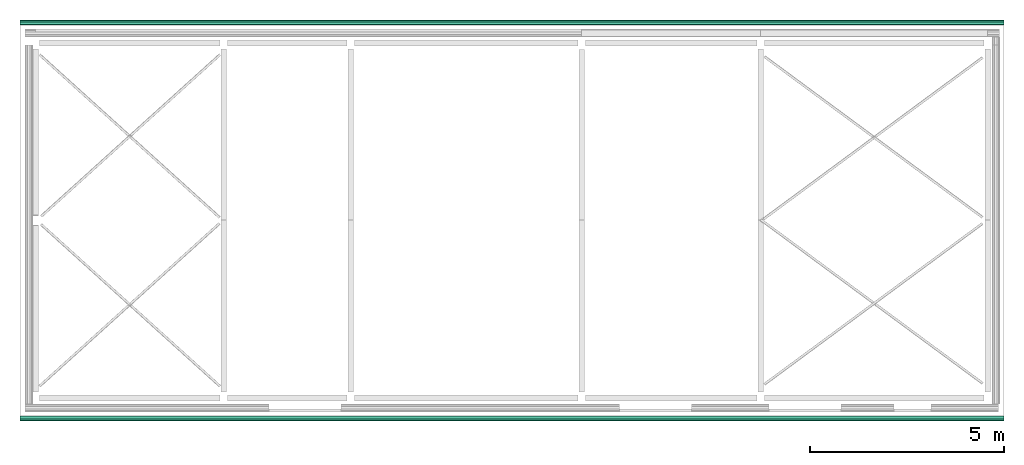
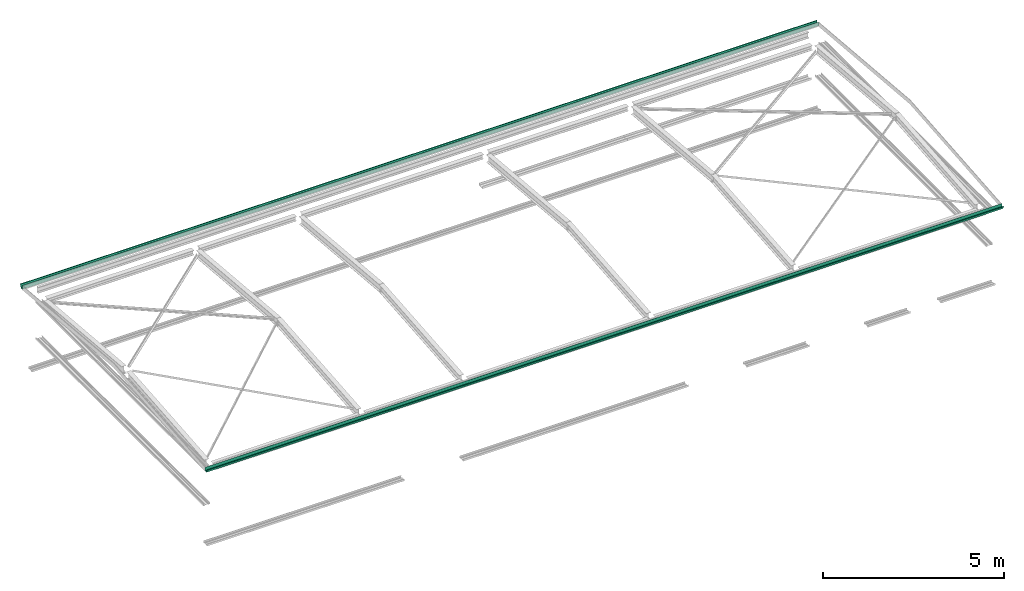
# One storey, part 4 of 8: 1 flow segment.
"""IFC2X3 building model written with IfcOpenShell, lengths in millimetres."""

from ifc_helpers import new_model, entity, si_unit, converted_unit, money_unit, direction, frame, origin_with_axes, place, context, subcontext, project, spatial, faceted_brep, material, material_list, type_object, element, save


model = new_model("IFC2X3")

# Units and contexts
model_context = context("Model", 3, precision=1e-05, world=origin_with_axes(), true_north=direction((0.0, 1.0)))
body_context = subcontext(model_context, "Body", "Model", "MODEL_VIEW")
ifc_project = project(units=[si_unit("LENGTHUNIT", "METRE", prefix="MILLI"), si_unit("AREAUNIT", "SQUARE_METRE"), si_unit("VOLUMEUNIT", "CUBIC_METRE"), converted_unit("PLANEANGLEUNIT", "DEGREE", entity("IfcPlaneAngleMeasure", 0.0174532925199), si_unit("PLANEANGLEUNIT", "RADIAN"), dimensions=[0, 0, 0, 0, 0, 0, 0]), si_unit("SOLIDANGLEUNIT", "STERADIAN"), money_unit("USD"), converted_unit("TIMEUNIT", "Year", entity("IfcTimeMeasure", 31556926.0), si_unit("TIMEUNIT", "SECOND"), dimensions=[0, 0, 0, 0, 0, 0, 0]), si_unit("MASSUNIT", "GRAM"), si_unit("THERMODYNAMICTEMPERATUREUNIT", "DEGREE_CELSIUS"), si_unit("LUMINOUSINTENSITYUNIT", "LUMEN")], contexts=[model_context])

# Site, building, storey
site_placement = place(None, origin_with_axes())
site = spatial("IfcSite", under=ifc_project, at=site_placement, CompositionType="ELEMENT")
building_placement = place(site_placement, origin_with_axes())
building = spatial("IfcBuilding", under=site, at=building_placement, CompositionType="ELEMENT")
storey_placement = place(building_placement, frame((0.0, 0.0, 74215.0), z_axis=(0.0, 0.0, 1.0), x_axis=(1.0, 0.0, 0.0)))
storey = spatial("IfcBuildingStorey", under=building, at=storey_placement, CompositionType="ELEMENT", Elevation=74215.0)

# Flow segment
ifc_material = material(Name="IFC Building Material")
ifc_material_list = material_list([ifc_material, ifc_material])
pipe_segment_type = type_object("IfcPipeSegmentType", Name="Gutter:Standard", PredefinedType="GUTTER")
flow_segment_placement = place(storey_placement, frame((-8525.22088657, -1586.32006319, 126.624724342), z_axis=(0.0, 0.0, 1.0), x_axis=(1.0, 0.0, 0.0)))
element("IfcFlowSegment", 1, at=flow_segment_placement, inside=storey, type_object=pipe_segment_type, material=ifc_material_list, Name="Gutter:Standard", ObjectType="Gutter:Standard", context=body_context, shape_type="Brep", body=[
    faceted_brep([(0.0, 10202.5999698, 0.0), (0.0, 10276.7999698, 0.0), (25352.2504249, 10276.7999698, 0.0), (25352.2504249, 10202.5999698, 0.0), (0.0, 10202.5999698, 124.912232528), (0.0, 10205.7749698, 124.912232528), (0.0, 10205.7749698, 3.175), (0.0, 10274.4376725, 3.175), (0.0, 10312.5376725, 102.687232528), (0.0, 10324.4249698, 102.687232528), (0.0, 10324.4249698, 109.037232528), (0.0, 10314.8999698, 109.037232528), (0.0, 10314.8999698, 112.212232528), (0.0, 10327.5999698, 112.212232528), (0.0, 10327.5999698, 99.5122325277), (0.0, 10314.8999698, 99.5122325277), (25352.2504249, 10314.8999698, 99.5122325277), (25352.2504249, 10327.5999698, 99.5122325277), (25352.2504249, 10327.5999698, 112.212232528), (25352.2504249, 10314.8999698, 112.212232528), (25352.2504249, 10314.8999698, 109.037232528), (25352.2504249, 10324.4249698, 109.037232528), (25352.2504249, 10324.4249698, 102.687232528), (25352.2504249, 10312.5376725, 102.687232528), (25352.2504249, 10274.4376725, 3.175), (25352.2504249, 10205.7749698, 3.175), (25352.2504249, 10205.7749698, 124.912232528), (25352.2504249, 10202.5999698, 124.912232528)], [[[0, 1, 2, 3]], [[0, 4, 5, 6, 7, 8, 9, 10, 11, 12, 13, 14, 15, 1]], [[1, 15, 16, 2]], [[3, 2, 16, 17, 18, 19, 20, 21, 22, 23, 24, 25, 26, 27]], [[4, 0, 3, 27]], [[5, 4, 27, 26]], [[6, 5, 26, 25]], [[7, 6, 25, 24]], [[8, 7, 24, 23]], [[9, 8, 23, 22]], [[10, 9, 22, 21]], [[11, 10, 21, 20]], [[12, 11, 20, 19]], [[13, 12, 19, 18]], [[14, 13, 18, 17]], [[15, 14, 17, 16]]]),
    faceted_brep([(0.0, 125.0, 0.0), (0.0, 125.0, 124.912232528), (25352.2504249, 125.0, 124.912232528), (25352.2504249, 125.0, 0.0), (0.0, 50.8, 0.0), (0.0, 12.7, 99.5122325277), (0.0, 0.0, 99.5122325277), (0.0, 0.0, 112.212232528), (0.0, 12.7, 112.212232528), (0.0, 12.7, 109.037232528), (0.0, 3.17500000001, 109.037232528), (0.0, 3.17500000001, 102.687232528), (0.0, 15.0622973166, 102.687232528), (0.0, 53.1622973166, 3.17500000001), (0.0, 121.825, 3.17500000001), (0.0, 121.825, 124.912232528), (25352.2504249, 121.825, 124.912232528), (25352.2504249, 121.825, 3.17500000001), (25352.2504249, 53.1622973166, 3.17500000001), (25352.2504249, 15.0622973166, 102.687232528), (25352.2504249, 3.17500000001, 102.687232528), (25352.2504249, 3.17500000001, 109.037232528), (25352.2504249, 12.7, 109.037232528), (25352.2504249, 12.7, 112.212232528), (25352.2504249, 0.0, 112.212232528), (25352.2504249, 0.0, 99.5122325277), (25352.2504249, 12.7, 99.5122325277), (25352.2504249, 50.8, 0.0)], [[[0, 1, 2, 3]], [[0, 4, 5, 6, 7, 8, 9, 10, 11, 12, 13, 14, 15, 1]], [[1, 15, 16, 2]], [[3, 2, 16, 17, 18, 19, 20, 21, 22, 23, 24, 25, 26, 27]], [[4, 0, 3, 27]], [[5, 4, 27, 26]], [[6, 5, 26, 25]], [[7, 6, 25, 24]], [[8, 7, 24, 23]], [[9, 8, 23, 22]], [[10, 9, 22, 21]], [[11, 10, 21, 20]], [[12, 11, 20, 19]], [[13, 12, 19, 18]], [[14, 13, 18, 17]], [[15, 14, 17, 16]]]),
])

save(model, "model.ifc")
